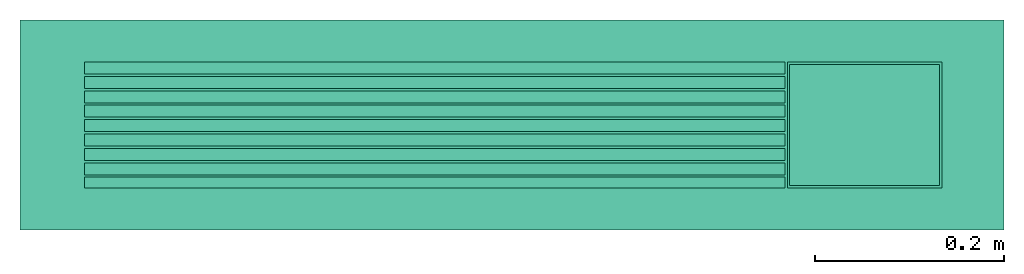
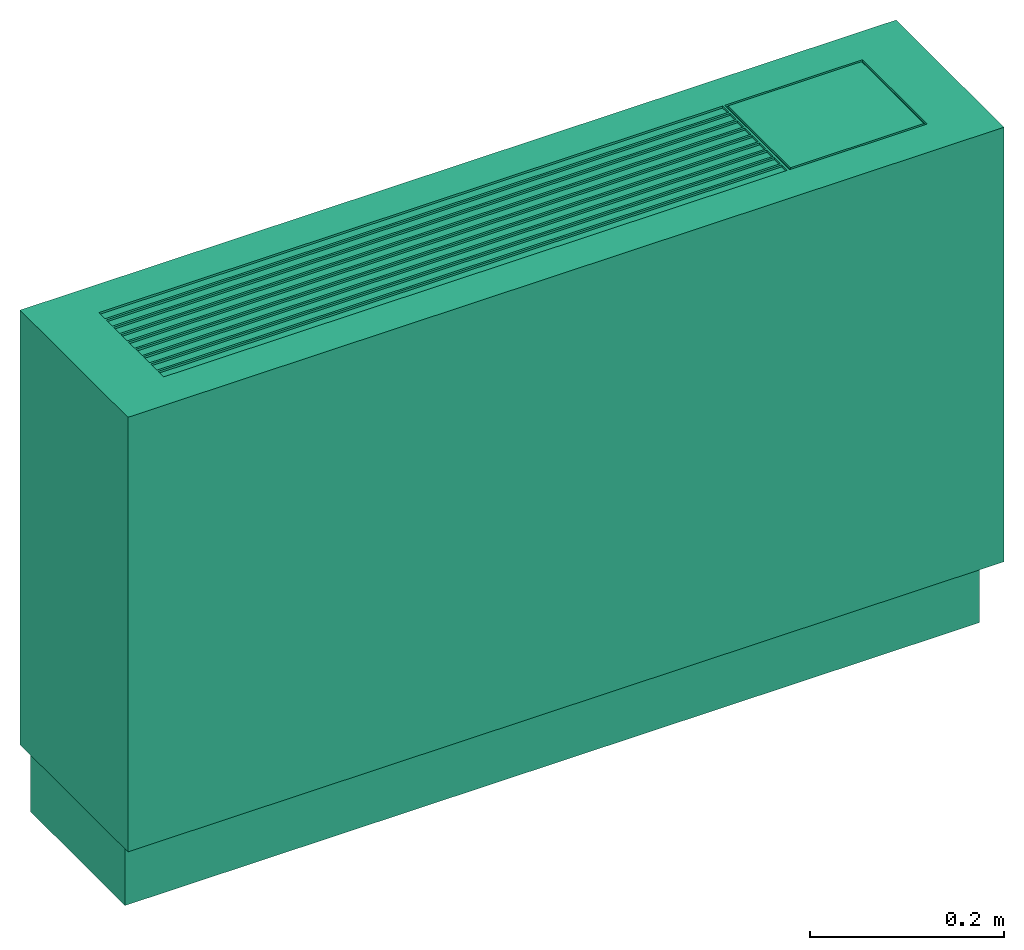
# One storey: 1 energy conversion device.
"""IFC2X3 building model written with IfcOpenShell, lengths in metres."""

from ifc_helpers import new_model, entity, si_unit, converted_unit, origin, origin_with_axes, place, context, subcontext, project, spatial, faceted_brep, type_object, element, save


model = new_model("IFC2X3")

# Units and contexts
model_context = context("Model", 3, precision=1e-05, world=origin())
body_context = subcontext(model_context, "Body", "Model", "MODEL_VIEW")
ifc_project = project(units=[si_unit("LENGTHUNIT", "METRE"), si_unit("AREAUNIT", "SQUARE_METRE"), si_unit("VOLUMEUNIT", "CUBIC_METRE"), converted_unit("PLANEANGLEUNIT", "DEGREE", entity("IfcPlaneAngleMeasure", 0.0174532925199433), si_unit("PLANEANGLEUNIT", "RADIAN"), dimensions=[0, 0, 0, 0, 0, 0, 0]), si_unit("SOLIDANGLEUNIT", "STERADIAN"), si_unit("MASSUNIT", "GRAM"), si_unit("TIMEUNIT", "SECOND"), si_unit("THERMODYNAMICTEMPERATUREUNIT", "DEGREE_CELSIUS"), si_unit("LUMINOUSINTENSITYUNIT", "LUMEN")], contexts=[model_context])

# Site, building, storey
site_placement = place(None, origin_with_axes())
site = spatial("IfcSite", under=ifc_project, at=site_placement, CompositionType="ELEMENT")
building_placement = place(site_placement, origin_with_axes())
building = spatial("IfcBuilding", under=site, at=building_placement, CompositionType="ELEMENT")
storey_placement = place(building_placement, origin_with_axes())
storey = spatial("IfcBuildingStorey", under=building, at=storey_placement, CompositionType="ELEMENT", Elevation=0.0)

# Energy conversion device
heat_exchanger_type = type_object("IfcHeatExchangerType", Name="Vertical Exposed Fan Coil Unit (FCU)", PredefinedType="NOTDEFINED")
energy_conversion_device_placement = place(storey_placement, origin_with_axes())
element("IfcEnergyConversionDevice", 1, at=energy_conversion_device_placement, inside=storey, type_object=heat_exchanger_type, Name="Vertical Exposed Fan Coil Unit (FCU)", context=body_context, shape_type="Brep", body=[
    faceted_brep([(0.455168001937865, 0.066675, 0.635), (0.291338006782532, 0.066675, 0.635), (0.291338006782532, 0.066675, 0.63245999031067), (0.455168001937865, 0.066675, 0.63245999031067), (0.288797997093201, -0.066675, 0.635), (0.288797997093201, -0.066675, 0.63245999031067), (-0.452627992248535, -0.066675, 0.63245999031067), (-0.452627992248535, -0.066675, 0.635), (0.293877992248535, 0.0641350024223327, 0.63245999031067), (0.452627992248535, 0.0641350024223327, 0.63245999031067), (0.291338006782532, -0.066675, 0.63245999031067), (0.293877992248535, -0.0641350024223327, 0.63245999031067), (0.455168001937865, -0.066675, 0.63245999031067), (0.452627992248535, -0.0641350024223327, 0.63245999031067), (0.5207, -0.111125, 0.0889), (0.5207, -0.111125, 0.635), (-0.5207, -0.111125, 0.635), (-0.5207, -0.111125, 0.0889), (0.508, 0.111125, 1.06886732918974e-17), (0.508, -0.0831850024223327, 1.35329593820862e-17), (-0.508, -0.0831850024223327, 1.45698277229407e-17), (-0.508, 0.111125, 1.17255416327518e-17), (-0.508, 0.111125, 0.0889), (-0.5207, 0.111125, 0.635), (0.5207, 0.111125, 0.635), (0.508, 0.111125, 0.0889), (-0.5207, 0.111125, 0.0889), (0.5207, 0.111125, 0.0889), (-0.452627992248535, -0.0552450048446654, 0.635), (-0.452627992248535, -0.0527049951553345, 0.635), (-0.452627992248535, -0.0400049951553346, 0.635), (-0.452627992248535, -0.0374649975776673, 0.635), (-0.452627992248535, -0.0247649975776672, 0.635), (-0.452627992248535, -0.022225, 0.635), (-0.452627992248535, -0.009525, 0.635), (-0.452627992248535, -0.00698500242233277, 0.635), (-0.452627992248535, 0.00571499757766723, 0.635), (0.288797997093201, -0.0400049951553346, 0.635), (0.288797997093201, -0.0527049951553345, 0.635), (0.291338006782532, -0.066675, 0.635), (0.455168001937865, -0.066675, 0.635), (0.288797997093201, -0.0552450048446654, 0.635), (0.288797997093201, -0.0374649975776673, 0.635), (0.288797997093201, -0.0247649975776672, 0.635), (0.288797997093201, -0.022225, 0.635), (0.288797997093201, -0.00698500242233277, 0.635), (0.288797997093201, -0.009525, 0.635), (0.288797997093201, 0.00571499757766723, 0.635), (-0.452627992248535, 0.00825499515533448, 0.635), (-0.452627992248535, 0.0209550012111664, 0.635), (-0.452627992248535, 0.0234949987888336, 0.635), (-0.452627992248535, 0.0387350024223327, 0.635), (-0.452627992248535, 0.0361949987888335, 0.635), (-0.452627992248535, 0.0514350024223327, 0.635), (-0.452627992248535, 0.053975, 0.635), (-0.452627992248535, 0.066675, 0.635), (0.288797997093201, 0.066675, 0.635), (0.288797997093201, 0.00825499515533448, 0.635), (0.288797997093201, 0.0209550012111664, 0.635), (0.288797997093201, 0.0234949987888336, 0.635), (0.288797997093201, 0.0361949987888335, 0.635), (0.288797997093201, 0.0387350024223327, 0.635), (0.288797997093201, 0.0514350024223327, 0.635), (0.288797997093201, 0.053975, 0.635), (-0.508, -0.0831850024223327, 0.0889), (0.508, -0.0831850024223327, 0.0889), (-0.452627992248535, 0.066675, 0.63245999031067), (0.288797997093201, 0.066675, 0.63245999031067), (0.452627992248535, -0.0641350024223327, 0.635), (0.293877992248535, -0.0641350024223327, 0.635), (0.452627992248535, 0.0641350024223327, 0.635), (0.293877992248535, 0.0641350024223327, 0.635), (-0.452627992248535, 0.0234949987888336, 0.63245999031067), (-0.452627992248535, 0.0361949987888335, 0.63245999031067), (-0.452627992248535, 0.0387350024223327, 0.63245999031067), (-0.452627992248535, 0.0514350024223327, 0.63245999031067), (0.288797997093201, 0.0514350024223327, 0.63245999031067), (0.288797997093201, 0.0387350024223327, 0.63245999031067), (-0.452627992248535, -0.0552450048446654, 0.63245999031067), (0.288797997093201, -0.0552450048446654, 0.63245999031067), (0.288797997093201, 0.053975, 0.63245999031067), (-0.452627992248535, 0.053975, 0.63245999031067), (-0.452627992248535, -0.0527049951553345, 0.63245999031067), (-0.452627992248535, -0.0400049951553346, 0.63245999031067), (0.288797997093201, -0.0400049951553346, 0.63245999031067), (0.288797997093201, -0.0527049951553345, 0.63245999031067), (-0.452627992248535, -0.0374649975776673, 0.63245999031067), (-0.452627992248535, -0.0247649975776672, 0.63245999031067), (0.288797997093201, -0.0247649975776672, 0.63245999031067), (0.288797997093201, -0.0374649975776673, 0.63245999031067), (-0.452627992248535, -0.022225, 0.63245999031067), (-0.452627992248535, -0.009525, 0.63245999031067), (0.288797997093201, -0.009525, 0.63245999031067), (0.288797997093201, -0.022225, 0.63245999031067), (-0.452627992248535, -0.00698500242233277, 0.63245999031067), (-0.452627992248535, 0.00571499757766723, 0.63245999031067), (0.288797997093201, 0.00571499757766723, 0.63245999031067), (0.288797997093201, -0.00698500242233277, 0.63245999031067), (-0.452627992248535, 0.00825499515533448, 0.63245999031067), (-0.452627992248535, 0.0209550012111664, 0.63245999031067), (0.288797997093201, 0.0209550012111664, 0.63245999031067), (0.288797997093201, 0.00825499515533448, 0.63245999031067), (0.288797997093201, 0.0361949987888335, 0.63245999031067), (0.288797997093201, 0.0234949987888336, 0.63245999031067), (-0.452627992248535, 0.066675, 0.629919980621337), (0.288797997093201, 0.066675, 0.629919980621337), (-0.452627992248535, -0.066675, 0.629919980621337), (0.288797997093201, -0.066675, 0.629919980621337)], [[[0, 1, 2]], [[2, 3, 0]], [[4, 5, 6]], [[6, 7, 4]], [[8, 9, 3]], [[3, 2, 8]], [[2, 10, 11]], [[11, 8, 2]], [[12, 3, 9]], [[9, 13, 12]], [[13, 11, 10]], [[10, 12, 13]], [[14, 15, 16]], [[16, 17, 14]], [[18, 19, 20]], [[20, 21, 18]], [[22, 23, 24]], [[24, 25, 22]], [[26, 23, 22]], [[22, 25, 18]], [[18, 21, 22]], [[25, 24, 27]], [[7, 16, 15]], [[15, 4, 7]], [[28, 16, 7]], [[16, 28, 29]], [[29, 30, 16]], [[16, 30, 31]], [[16, 31, 32]], [[16, 33, 34]], [[16, 34, 35]], [[33, 16, 32]], [[35, 36, 16]], [[37, 38, 39]], [[40, 39, 15]], [[4, 15, 39]], [[39, 38, 41]], [[40, 15, 24]], [[24, 0, 40]], [[42, 37, 39]], [[4, 39, 41]], [[43, 42, 39]], [[44, 43, 39]], [[45, 46, 39]], [[47, 45, 39]], [[46, 44, 39]], [[39, 1, 47]], [[23, 36, 48]], [[23, 49, 50]], [[49, 23, 48]], [[51, 23, 52]], [[50, 52, 23]], [[53, 23, 51]], [[23, 53, 54]], [[23, 54, 55]], [[23, 16, 36]], [[56, 24, 23]], [[23, 55, 56]], [[57, 1, 58]], [[59, 1, 60]], [[60, 1, 61]], [[58, 1, 59]], [[62, 1, 63]], [[1, 56, 63]], [[0, 24, 1]], [[56, 1, 24]], [[62, 61, 1]], [[57, 47, 1]], [[64, 17, 26]], [[26, 22, 64]], [[25, 27, 14]], [[14, 65, 25]], [[17, 64, 65]], [[65, 14, 17]], [[19, 65, 64]], [[64, 20, 19]], [[15, 14, 27]], [[27, 24, 15]], [[16, 23, 26]], [[26, 17, 16]], [[20, 64, 22]], [[22, 21, 20]], [[25, 65, 19]], [[19, 18, 25]], [[56, 55, 66]], [[66, 67, 56]], [[0, 3, 12]], [[12, 40, 0]], [[13, 68, 69]], [[69, 11, 13]], [[70, 68, 13]], [[13, 9, 70]], [[9, 8, 71]], [[71, 70, 9]], [[69, 71, 8]], [[8, 11, 69]], [[40, 12, 10]], [[10, 39, 40]], [[68, 70, 71]], [[71, 69, 68]], [[72, 73, 52]], [[52, 50, 72]], [[74, 75, 53]], [[53, 51, 74]], [[61, 62, 76]], [[76, 77, 61]], [[6, 78, 28]], [[28, 7, 6]], [[4, 41, 79]], [[79, 5, 4]], [[10, 2, 1]], [[1, 39, 10]], [[63, 56, 67]], [[67, 80, 63]], [[81, 66, 55]], [[55, 54, 81]], [[82, 83, 30]], [[30, 29, 82]], [[38, 37, 84]], [[84, 85, 38]], [[86, 87, 32]], [[32, 31, 86]], [[42, 43, 88]], [[88, 89, 42]], [[90, 91, 34]], [[34, 33, 90]], [[44, 46, 92]], [[92, 93, 44]], [[94, 95, 36]], [[36, 35, 94]], [[45, 47, 96]], [[96, 97, 45]], [[98, 99, 49]], [[49, 48, 98]], [[57, 58, 100]], [[100, 101, 57]], [[59, 60, 102]], [[102, 103, 59]], [[67, 66, 104]], [[104, 105, 67]], [[104, 66, 81]], [[104, 75, 74]], [[74, 73, 104]], [[104, 81, 75]], [[73, 74, 51]], [[51, 52, 73]], [[72, 104, 73]], [[99, 104, 72]], [[98, 104, 99]], [[95, 98, 48]], [[48, 36, 95]], [[98, 95, 104]], [[72, 50, 49]], [[49, 99, 72]], [[104, 95, 94]], [[94, 106, 104]], [[53, 81, 54]], [[75, 81, 53]], [[91, 94, 35]], [[35, 34, 91]], [[106, 94, 91]], [[87, 90, 33]], [[33, 32, 87]], [[106, 90, 87]], [[90, 106, 91]], [[78, 106, 82]], [[83, 86, 31]], [[31, 30, 83]], [[106, 86, 83]], [[106, 83, 82]], [[78, 6, 106]], [[87, 86, 106]], [[78, 82, 29]], [[29, 28, 78]], [[107, 105, 104]], [[104, 106, 107]], [[6, 5, 107]], [[107, 106, 6]], [[107, 5, 79]], [[107, 85, 84]], [[84, 89, 107]], [[85, 107, 79]], [[107, 89, 88]], [[107, 93, 92]], [[107, 92, 97]], [[97, 92, 46]], [[46, 45, 97]], [[93, 107, 88]], [[93, 88, 43]], [[43, 44, 93]], [[97, 96, 107]], [[89, 84, 37]], [[37, 42, 89]], [[38, 79, 41]], [[85, 79, 38]], [[101, 96, 47]], [[47, 57, 101]], [[105, 96, 101]], [[100, 58, 59]], [[59, 103, 100]], [[105, 100, 103]], [[100, 105, 101]], [[77, 105, 102]], [[103, 102, 105]], [[105, 77, 76]], [[76, 80, 105]], [[102, 60, 61]], [[61, 77, 102]], [[105, 107, 96]], [[105, 80, 67]], [[80, 62, 63]], [[80, 76, 62]]]),
    faceted_brep([(0.288797997093201, -0.0552450048446654, 0.63245999031067), (-0.452627992248535, -0.0552450048446654, 0.63245999031067), (-0.452627992248535, -0.066675, 0.63245999031067), (0.288797997093201, -0.066675, 0.63245999031067), (0.288797997093201, 0.066675, 0.63245999031067), (-0.452627992248535, 0.066675, 0.63245999031067), (-0.452627992248535, 0.053975, 0.63245999031067), (0.288797997093201, 0.053975, 0.63245999031067), (0.288797997093201, 0.0234949987888336, 0.63245999031067), (-0.452627992248535, 0.0234949987888336, 0.63245999031067), (-0.452627992248535, 0.0234949987888336, 0.635), (0.288797997093201, 0.0234949987888336, 0.635), (0.288797997093201, 0.0361949987888335, 0.63245999031067), (0.288797997093201, 0.0361949987888335, 0.635), (-0.452627992248535, 0.0361949987888335, 0.635), (-0.452627992248535, 0.0361949987888335, 0.63245999031067), (0.288797997093201, 0.0514350024223327, 0.63245999031067), (0.288797997093201, 0.0514350024223327, 0.635), (-0.452627992248535, 0.0514350024223327, 0.635), (-0.452627992248535, 0.0514350024223327, 0.63245999031067), (0.288797997093201, -0.0552450048446654, 0.635), (-0.452627992248535, -0.0552450048446654, 0.635), (-0.452627992248535, 0.053975, 0.635), (0.288797997093201, 0.053975, 0.635), (0.288797997093201, -0.0400049951553346, 0.63245999031067), (0.288797997093201, -0.0400049951553346, 0.635), (-0.452627992248535, -0.0400049951553346, 0.635), (-0.452627992248535, -0.0400049951553346, 0.63245999031067), (0.288797997093201, -0.0247649975776672, 0.63245999031067), (0.288797997093201, -0.0247649975776672, 0.635), (-0.452627992248535, -0.0247649975776672, 0.635), (-0.452627992248535, -0.0247649975776672, 0.63245999031067), (0.288797997093201, -0.009525, 0.63245999031067), (0.288797997093201, -0.009525, 0.635), (-0.452627992248535, -0.009525, 0.635), (-0.452627992248535, -0.009525, 0.63245999031067), (0.288797997093201, 0.00571499757766723, 0.63245999031067), (0.288797997093201, 0.00571499757766723, 0.635), (-0.452627992248535, 0.00571499757766723, 0.635), (-0.452627992248535, 0.00571499757766723, 0.63245999031067), (0.288797997093201, 0.0209550012111664, 0.63245999031067), (0.288797997093201, 0.0209550012111664, 0.635), (-0.452627992248535, 0.0209550012111664, 0.635), (-0.452627992248535, 0.0209550012111664, 0.63245999031067), (0.288797997093201, 0.0387350024223327, 0.63245999031067), (-0.452627992248535, 0.0387350024223327, 0.63245999031067), (-0.452627992248535, 0.0387350024223327, 0.635), (0.288797997093201, 0.0387350024223327, 0.635), (0.288797997093201, -0.0527049951553345, 0.63245999031067), (-0.452627992248535, -0.0527049951553345, 0.63245999031067), (-0.452627992248535, -0.0527049951553345, 0.635), (0.288797997093201, -0.0527049951553345, 0.635), (0.288797997093201, -0.0374649975776673, 0.63245999031067), (-0.452627992248535, -0.0374649975776673, 0.63245999031067), (-0.452627992248535, -0.0374649975776673, 0.635), (0.288797997093201, -0.0374649975776673, 0.635), (0.288797997093201, -0.022225, 0.63245999031067), (-0.452627992248535, -0.022225, 0.63245999031067), (-0.452627992248535, -0.022225, 0.635), (0.288797997093201, -0.022225, 0.635), (0.288797997093201, -0.00698500242233277, 0.63245999031067), (-0.452627992248535, -0.00698500242233277, 0.63245999031067), (-0.452627992248535, -0.00698500242233277, 0.635), (0.288797997093201, -0.00698500242233277, 0.635), (0.288797997093201, 0.00825499515533448, 0.63245999031067), (-0.452627992248535, 0.00825499515533448, 0.63245999031067), (-0.452627992248535, 0.00825499515533448, 0.635), (0.288797997093201, 0.00825499515533448, 0.635), (0.288797997093201, 0.066675, 0.629919980621337), (-0.452627992248535, 0.066675, 0.629919980621337), (-0.452627992248535, -0.066675, 0.629919980621337), (0.288797997093201, -0.066675, 0.629919980621337)], [[[0, 1, 2]], [[2, 3, 0]], [[4, 5, 6]], [[6, 7, 4]], [[8, 9, 10]], [[10, 11, 8]], [[12, 13, 14]], [[14, 15, 12]], [[16, 17, 18]], [[18, 19, 16]], [[0, 20, 21]], [[21, 1, 0]], [[7, 6, 22]], [[22, 23, 7]], [[24, 25, 26]], [[26, 27, 24]], [[28, 29, 30]], [[30, 31, 28]], [[32, 33, 34]], [[34, 35, 32]], [[36, 37, 38]], [[38, 39, 36]], [[40, 41, 42]], [[42, 43, 40]], [[44, 45, 46]], [[46, 47, 44]], [[48, 49, 50]], [[50, 51, 48]], [[52, 53, 54]], [[54, 55, 52]], [[56, 57, 58]], [[58, 59, 56]], [[60, 61, 62]], [[62, 63, 60]], [[64, 65, 66]], [[66, 67, 64]], [[12, 15, 9]], [[9, 8, 12]], [[40, 43, 65]], [[65, 64, 40]], [[36, 39, 61]], [[61, 60, 36]], [[32, 35, 57]], [[57, 56, 32]], [[28, 31, 53]], [[53, 52, 28]], [[24, 27, 49]], [[49, 48, 24]], [[16, 19, 45]], [[45, 44, 16]], [[4, 68, 69]], [[69, 5, 4]], [[69, 6, 5]], [[69, 45, 19]], [[45, 69, 15]], [[69, 19, 6]], [[15, 14, 46]], [[46, 45, 15]], [[9, 15, 69]], [[43, 9, 69]], [[65, 43, 69]], [[39, 38, 66]], [[66, 65, 39]], [[65, 69, 39]], [[9, 43, 42]], [[42, 10, 9]], [[69, 70, 61]], [[61, 39, 69]], [[18, 22, 6]], [[19, 18, 6]], [[35, 34, 62]], [[62, 61, 35]], [[70, 35, 61]], [[31, 30, 58]], [[58, 57, 31]], [[70, 31, 57]], [[57, 35, 70]], [[1, 49, 70]], [[27, 26, 54]], [[54, 53, 27]], [[70, 27, 53]], [[70, 49, 27]], [[1, 70, 2]], [[31, 70, 53]], [[1, 21, 50]], [[50, 49, 1]], [[71, 70, 69]], [[69, 68, 71]], [[20, 51, 50]], [[50, 21, 20]], [[25, 55, 54]], [[54, 26, 25]], [[29, 59, 58]], [[58, 30, 29]], [[33, 63, 62]], [[62, 34, 33]], [[37, 67, 66]], [[66, 38, 37]], [[41, 11, 10]], [[10, 42, 41]], [[13, 47, 46]], [[46, 14, 13]], [[17, 23, 22]], [[22, 18, 17]], [[2, 70, 71]], [[71, 3, 2]], [[71, 0, 3]], [[71, 24, 48]], [[24, 71, 52]], [[48, 0, 71]], [[71, 28, 52]], [[71, 32, 56]], [[71, 60, 32]], [[60, 63, 33]], [[33, 32, 60]], [[56, 28, 71]], [[56, 59, 29]], [[29, 28, 56]], [[60, 71, 36]], [[52, 55, 25]], [[25, 24, 52]], [[51, 20, 0]], [[48, 51, 0]], [[64, 67, 37]], [[37, 36, 64]], [[68, 64, 36]], [[40, 8, 11]], [[11, 41, 40]], [[68, 8, 40]], [[40, 64, 68]], [[44, 12, 68]], [[8, 68, 12]], [[68, 16, 44]], [[16, 68, 7]], [[12, 44, 47]], [[47, 13, 12]], [[68, 36, 71]], [[68, 4, 7]], [[7, 23, 17]], [[7, 17, 16]]]),
])

save(model, "model.ifc")
